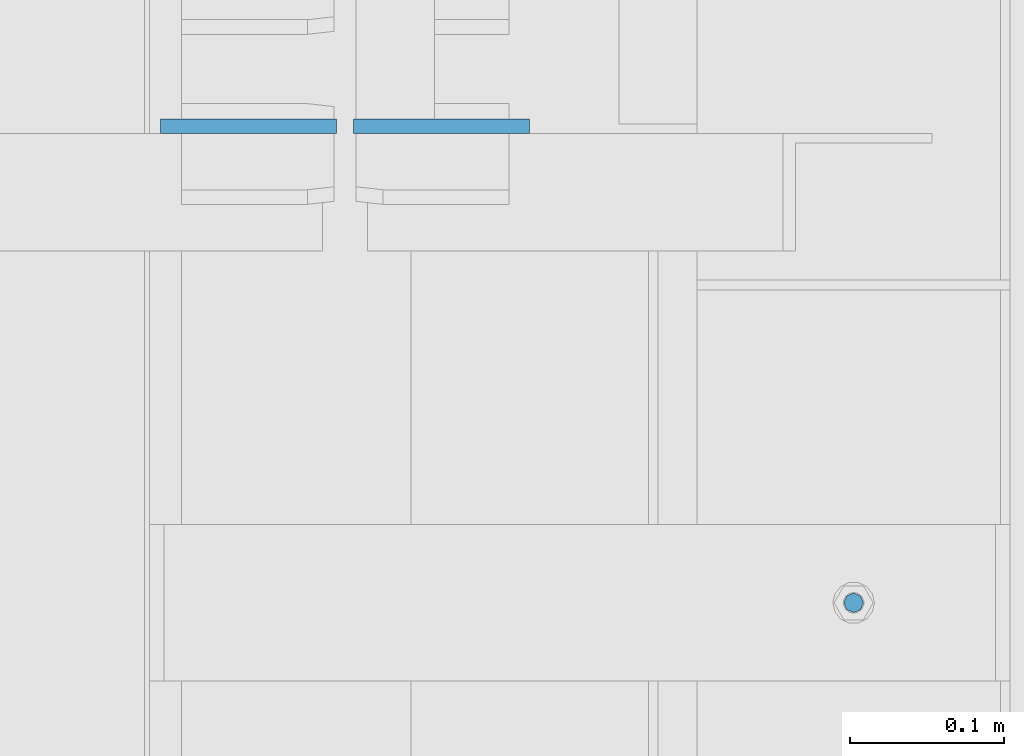
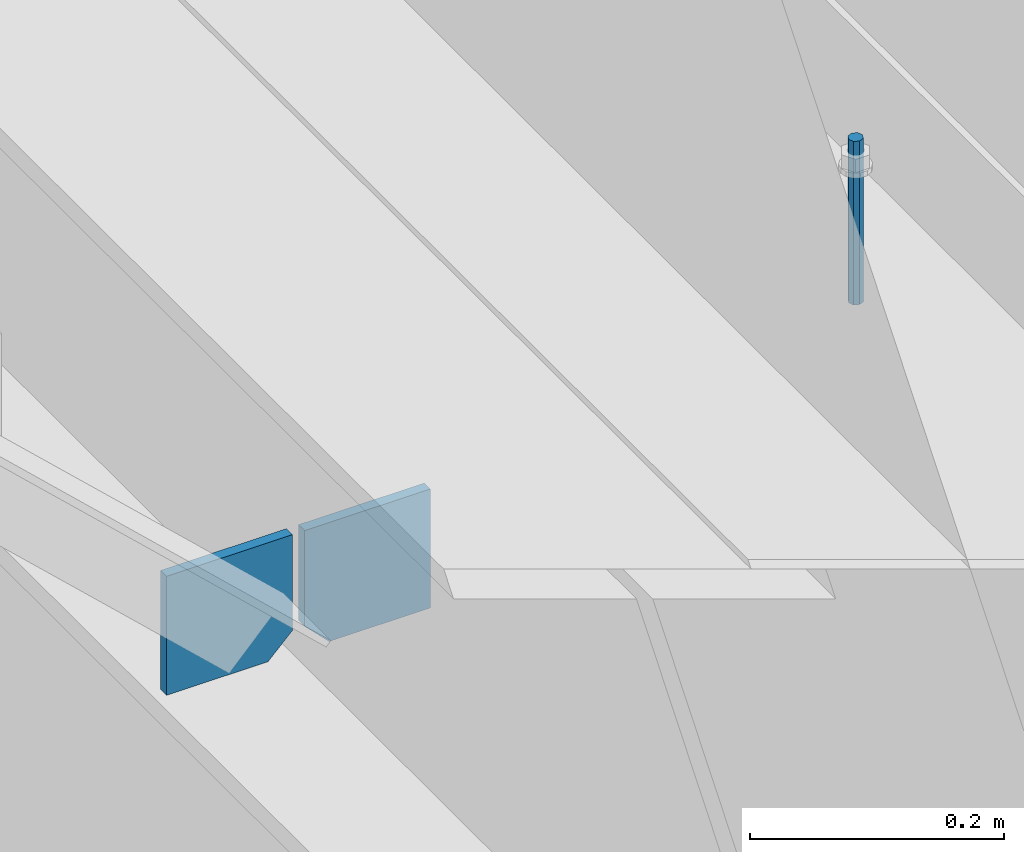
# One storey, part 445 of 1179: 3 columns, 1 element without a shape of its own.
"""IFC2X3 building model written with IfcOpenShell, lengths in millimetres."""

from ifc_helpers import new_model, si_unit, frame, origin_with_axes, place, context, subcontext, project, spatial, faceted_brep, material, type_object, element, aggregate, save


model = new_model("IFC2X3")

# Units and contexts
model_context = context("Model", 3, precision=1e-05, world=origin_with_axes())
body_context = subcontext(model_context, "Body", "Model", "MODEL_VIEW")
ifc_project = project(units=[si_unit("LENGTHUNIT", "METRE", prefix="MILLI"), si_unit("AREAUNIT", "SQUARE_METRE"), si_unit("VOLUMEUNIT", "CUBIC_METRE"), si_unit("MASSUNIT", "GRAM", prefix="KILO"), si_unit("TIMEUNIT", "SECOND"), si_unit("PLANEANGLEUNIT", "RADIAN"), si_unit("SOLIDANGLEUNIT", "STERADIAN"), si_unit("THERMODYNAMICTEMPERATUREUNIT", "DEGREE_CELSIUS"), si_unit("LUMINOUSINTENSITYUNIT", "LUMEN")], contexts=[model_context])

# Site, building, storey
site_placement = place(None, origin_with_axes())
site = spatial("IfcSite", under=ifc_project, at=site_placement, CompositionType="ELEMENT")
building_placement = place(site_placement, origin_with_axes())
building = spatial("IfcBuilding", under=site, at=building_placement, Name="Undefined", CompositionType="ELEMENT")
storey_placement = place(building_placement, origin_with_axes())
storey = spatial("IfcBuildingStorey", under=building, at=storey_placement, Name="Undefined", CompositionType="ELEMENT", Elevation=0.0)

# Assembly, columns
assembly_placement = place(storey_placement, origin_with_axes())
assembly = element("IfcElementAssembly", 1, at=assembly_placement, inside=storey, Name="BEAM", AssemblyPlace="NOTDEFINED", PredefinedType="RIGID_FRAME")
ifc_material_1 = material(Name="STEEL/A36")
column_type_1 = type_object("IfcColumnType", PredefinedType="NOTDEFINED")
column_1_placement = place(assembly_placement, frame((24245.09375, 20400.9625, 3702.05), z_axis=(1.0, 0.0, 0.0), x_axis=(0.0, 0.0, 1.0)))
column_1 = element("IfcColumn", 2, at=column_1_placement, type_object=column_type_1, material=ifc_material_1, Name="PLATE", context=body_context, shape_type="Brep", body=[
    faceted_brep([(22.2250000000004, 4.76250000000073, 57.1500000000015), (0.0, 4.76250000000073, 34.9249999999993), (0.0, -4.76250000000073, 34.9249999999993), (22.2250000000004, -4.76250000000073, 57.1500000000015), (114.300000000001, 4.76250000000073, 57.1500000000015), (114.300000000001, 4.76250000000073, -57.1500000000015), (0.0, 4.76250000000073, -57.1500000000015), (114.300000000001, -4.76250000000073, 57.1500000000015), (0.0, -4.76250000000073, -57.1500000000015), (114.300000000001, -4.76250000000073, -57.1500000000015)], [[[0, 1, 2, 3]], [[4, 5, 6, 1, 0]], [[7, 4, 0, 3]], [[8, 9, 7, 3, 2]], [[8, 6, 5, 9]], [[7, 9, 5, 4]], [[6, 8, 2, 1]]]),
])
column_2_placement = place(assembly_placement, frame((24370.50625, 20400.9625, 3702.05), z_axis=(-1.0, 0.0, 0.0), x_axis=(0.0, 0.0, 1.0)))
column_2 = element("IfcColumn", 3, at=column_2_placement, type_object=column_type_1, material=ifc_material_1, Name="PLATE", context=body_context, shape_type="Brep", body=[
    faceted_brep([(22.2250000000004, 4.76250000000073, 57.1500000000015), (0.0, 4.76250000000073, 34.9249999999993), (0.0, -4.76250000000073, 34.9249999999993), (22.2250000000004, -4.76250000000073, 57.1500000000015), (114.300000000001, 4.76250000000073, 57.1500000000015), (114.300000000001, 4.76250000000073, -57.1500000000015), (0.0, 4.76250000000073, -57.1500000000015), (114.300000000001, -4.76250000000073, 57.1500000000015), (0.0, -4.76250000000073, -57.1500000000015), (114.300000000001, -4.76250000000073, -57.1500000000015)], [[[0, 1, 2, 3]], [[4, 5, 6, 1, 0]], [[7, 4, 0, 3]], [[8, 9, 7, 3, 2]], [[8, 6, 5, 9]], [[7, 9, 5, 4]], [[6, 8, 2, 1]]]),
])
ifc_material_2 = material(Name="STEEL/A307")
column_type_2 = type_object("IfcColumnType", PredefinedType="NOTDEFINED")
column_3_placement = place(assembly_placement, frame((24638.0, 20091.4, 4108.45), z_axis=(0.0, 1.0, 0.0), x_axis=(0.0, 0.0, 1.0)))
column_3 = element("IfcColumn", 4, at=column_3_placement, type_object=column_type_2, material=ifc_material_2, Name="THREADED ROD", context=body_context, shape_type="Brep", body=[
    faceted_brep([(0.0, -6.34999999999854, 0.0), (0.0, -4.49012806053361, -4.49012806053452), (157.162499999999, -4.49012806053361, -4.49012806053361), (157.162499999999, -6.34999999999854, 0.0), (0.0, 0.0, -6.34999999999991), (157.162499999999, 0.0, -6.34999999999854), (0.0, 4.49012806053361, -4.49012806053452), (157.162499999999, 4.49012806053361, -4.49012806053361), (0.0, 6.34999999999854, 0.0), (157.162499999999, 6.34999999999854, 0.0), (0.0, 4.49012806053361, 4.49012806053452), (157.162499999999, 4.49012806053361, 4.49012806053361), (0.0, 0.0, 6.34999999999991), (157.162499999999, 0.0, 6.34999999999854), (0.0, -4.49012806053361, 4.49012806053452), (157.162499999999, -4.49012806053361, 4.49012806053361)], [[[0, 1, 2, 3]], [[1, 4, 5, 2]], [[4, 6, 7, 5]], [[6, 8, 9, 7]], [[8, 10, 11, 9]], [[10, 12, 13, 11]], [[12, 14, 15, 13]], [[14, 0, 3, 15]], [[5, 7, 9, 11, 13, 15, 3, 2]], [[14, 12, 10, 8, 6, 4, 1, 0]]]),
])
aggregate(assembly, [column_3, column_1, column_2])

save(model, "model.ifc")
